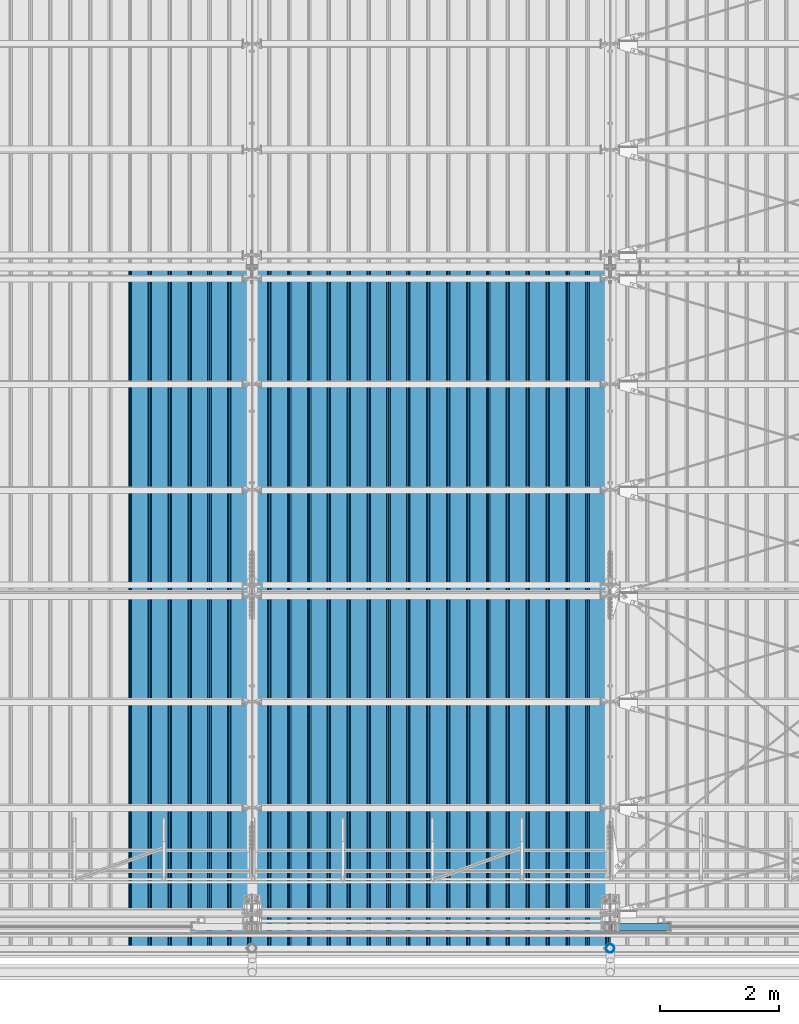
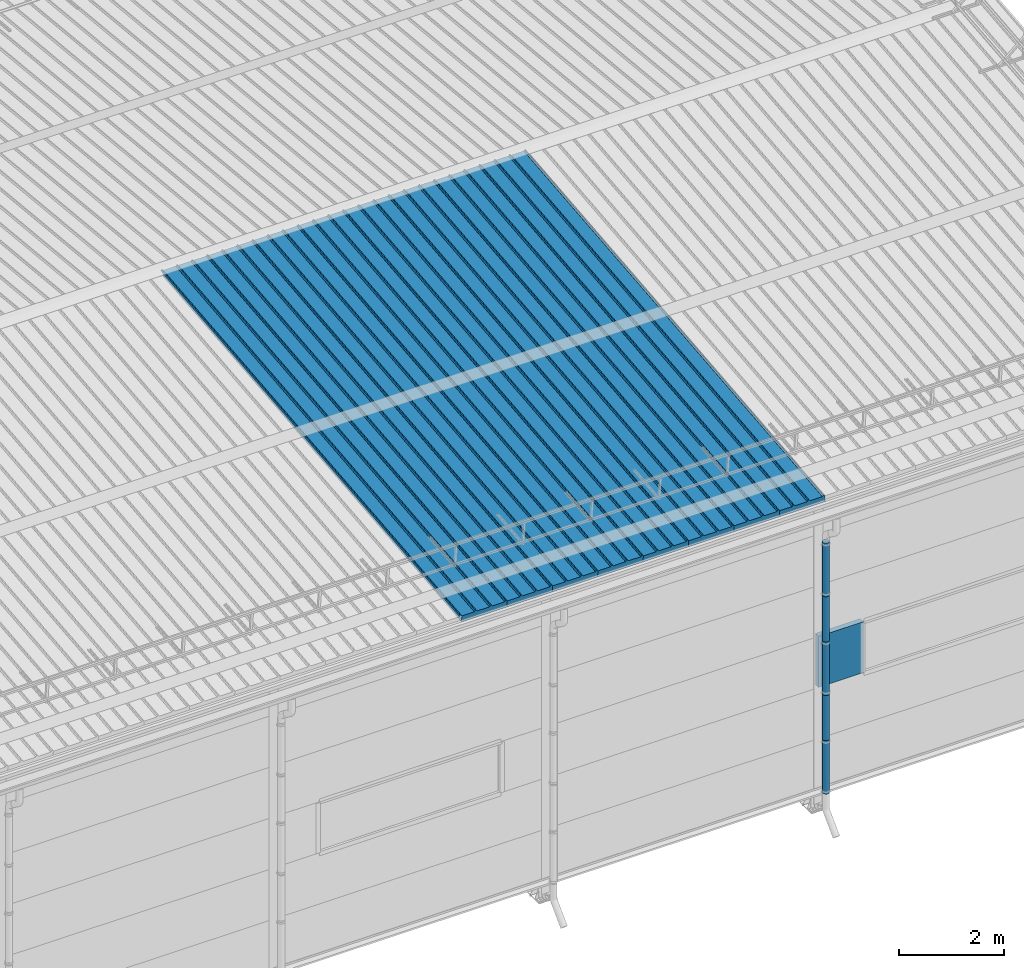
# One storey, part 65 of 709: 14 beams, 14 elements without a shape of their own.
"""IFC4 building model written with IfcOpenShell, lengths in millimetres."""

from ifc_helpers import new_model, si_unit, direction, frame, origin_with_axes, place, context, subcontext, project, spatial, line, indexed_curve, outline, extrude, material, element, aggregate, save


model = new_model("IFC4")

# Units and contexts
model_context = context("Model", 3, precision=0.2, world=origin_with_axes(), true_north=direction((0.0, 1.0)))
body_context = subcontext(model_context, "Body", "Model", "MODEL_VIEW")
ifc_project = project(units=[si_unit("LENGTHUNIT", "METRE", prefix="MILLI"), si_unit("AREAUNIT", "SQUARE_METRE"), si_unit("VOLUMEUNIT", "CUBIC_METRE"), si_unit("MASSUNIT", "GRAM", prefix="KILO"), si_unit("TIMEUNIT", "SECOND"), si_unit("PLANEANGLEUNIT", "RADIAN"), si_unit("SOLIDANGLEUNIT", "STERADIAN"), si_unit("THERMODYNAMICTEMPERATUREUNIT", "DEGREE_CELSIUS"), si_unit("LUMINOUSINTENSITYUNIT", "LUMEN")], contexts=[model_context])

# Site, building, storey
site_placement = place(None, origin_with_axes())
site = spatial("IfcSite", under=ifc_project, at=site_placement, CompositionType="ELEMENT")
building_placement = place(site_placement, origin_with_axes())
building = spatial("IfcBuilding", under=site, at=building_placement, Name="Undefined", CompositionType="ELEMENT")
storey_placement = place(building_placement, origin_with_axes())
storey = spatial("IfcBuildingStorey", under=building, at=storey_placement, Name="Undefined", CompositionType="ELEMENT", Elevation=0.0)

# Assembly, beam
assembly_1_placement = place(storey_placement, frame((39452.44, -410.89541, 7279.78979), z_axis=(1.0, 0.0, 0.0), x_axis=(0.0, 0.9950371902, 0.099503719)))
assembly_1 = element("IfcElementAssembly", 1, at=assembly_1_placement, inside=storey)
ifc_material_1 = material(Name="Insulation", Category="Insulation")
beam_1_placement = place(assembly_1_placement, origin_with_axes())
beam_1 = element("IfcBeam", 2, at=beam_1_placement, material=ifc_material_1, ObjectType="P-99", context=body_context, shape_type="SolidModel", body=[
    extrude(outline(indexed_curve([(-509.8453, 89.5), (-490.1547, 89.5), (-471.67949, 57.5), (-471.67949, -88.5), (-436.67949, -88.5), (-436.67949, -91.5), (562.55841, -91.5), (562.55841, -89.5), (527.55841, -89.5), (527.55841, 57.5), (510.2379, 88.5), (489.7621, 88.5), (472.44159, 58.5), (196.71923, 58.5), (177.66667, 91.5), (155.66667, 91.5), (136.61411, 58.5), (-136.61411, 58.5), (-155.66667, 91.5), (-177.66667, 91.5), (-196.71923, 58.5), (-469.94744, 58.5), (-489.0, 91.5), (-511.0, 91.5), (-527.16581, 63.5), (-525.43376, 62.5)], segments=[line(1, 2, 3, 4, 5, 6, 7, 8, 9, 10, 11, 12, 13, 14, 15, 16, 17, 18, 19, 20, 21, 22, 23, 24, 25, 26, 1)])), frame((0.0, 0.0, 0.0), z_axis=(-1.0, 0.0, 0.0), x_axis=(0.0, 0.0, 1.0)), (0.0, 0.0, -1.0), 11459.0),
])
aggregate(assembly_1, [beam_1])

assembly_2_placement = place(storey_placement, frame((38452.44, -410.89541, 7279.78979), z_axis=(1.0, 0.0, 0.0), x_axis=(0.0, 0.9950371902, 0.099503719)))
assembly_2 = element("IfcElementAssembly", 3, at=assembly_2_placement, inside=storey)
beam_2_placement = place(assembly_2_placement, origin_with_axes())
beam_2 = element("IfcBeam", 4, at=beam_2_placement, material=ifc_material_1, ObjectType="P-99", context=body_context, shape_type="SolidModel", body=[
    extrude(outline(indexed_curve([(-509.8453, 89.5), (-490.1547, 89.5), (-471.67949, 57.5), (-471.67949, -88.5), (-436.67949, -88.5), (-436.67949, -91.5), (562.55841, -91.5), (562.55841, -89.5), (527.55841, -89.5), (527.55841, 57.5), (510.2379, 88.5), (489.7621, 88.5), (472.44159, 58.5), (196.71923, 58.5), (177.66667, 91.5), (155.66667, 91.5), (136.61411, 58.5), (-136.61411, 58.5), (-155.66667, 91.5), (-177.66667, 91.5), (-196.71923, 58.5), (-469.94744, 58.5), (-489.0, 91.5), (-511.0, 91.5), (-527.16581, 63.5), (-525.43376, 62.5)], segments=[line(1, 2, 3, 4, 5, 6, 7, 8, 9, 10, 11, 12, 13, 14, 15, 16, 17, 18, 19, 20, 21, 22, 23, 24, 25, 26, 1)])), frame((0.0, 0.0, 0.0), z_axis=(-1.0, 0.0, 0.0), x_axis=(0.0, 0.0, 1.0)), (0.0, 0.0, -1.0), 11459.0),
])
aggregate(assembly_2, [beam_2])

assembly_3_placement = place(storey_placement, frame((37452.44, -410.89541, 7279.78979), z_axis=(1.0, 0.0, 0.0), x_axis=(0.0, 0.9950371902, 0.099503719)))
assembly_3 = element("IfcElementAssembly", 5, at=assembly_3_placement, inside=storey)
beam_3_placement = place(assembly_3_placement, origin_with_axes())
beam_3 = element("IfcBeam", 6, at=beam_3_placement, material=ifc_material_1, ObjectType="P-99", context=body_context, shape_type="SolidModel", body=[
    extrude(outline(indexed_curve([(-509.8453, 89.5), (-490.1547, 89.5), (-471.67949, 57.5), (-471.67949, -88.5), (-436.67949, -88.5), (-436.67949, -91.5), (562.55841, -91.5), (562.55841, -89.5), (527.55841, -89.5), (527.55841, 57.5), (510.2379, 88.5), (489.7621, 88.5), (472.44159, 58.5), (196.71923, 58.5), (177.66667, 91.5), (155.66667, 91.5), (136.61411, 58.5), (-136.61411, 58.5), (-155.66667, 91.5), (-177.66667, 91.5), (-196.71923, 58.5), (-469.94744, 58.5), (-489.0, 91.5), (-511.0, 91.5), (-527.16581, 63.5), (-525.43376, 62.5)], segments=[line(1, 2, 3, 4, 5, 6, 7, 8, 9, 10, 11, 12, 13, 14, 15, 16, 17, 18, 19, 20, 21, 22, 23, 24, 25, 26, 1)])), frame((0.0, 0.0, 0.0), z_axis=(-1.0, 0.0, 0.0), x_axis=(0.0, 0.0, 1.0)), (0.0, 0.0, -1.0), 11459.0),
])
aggregate(assembly_3, [beam_3])

assembly_4_placement = place(storey_placement, frame((36452.44, -410.89541, 7279.78979), z_axis=(1.0, 0.0, 0.0), x_axis=(0.0, 0.9950371902, 0.099503719)))
assembly_4 = element("IfcElementAssembly", 7, at=assembly_4_placement, inside=storey)
beam_4_placement = place(assembly_4_placement, origin_with_axes())
beam_4 = element("IfcBeam", 8, at=beam_4_placement, material=ifc_material_1, ObjectType="P-99", context=body_context, shape_type="SolidModel", body=[
    extrude(outline(indexed_curve([(-509.8453, 89.5), (-490.1547, 89.5), (-471.67949, 57.5), (-471.67949, -88.5), (-436.67949, -88.5), (-436.67949, -91.5), (562.55841, -91.5), (562.55841, -89.5), (527.55841, -89.5), (527.55841, 57.5), (510.2379, 88.5), (489.7621, 88.5), (472.44159, 58.5), (196.71923, 58.5), (177.66667, 91.5), (155.66667, 91.5), (136.61411, 58.5), (-136.61411, 58.5), (-155.66667, 91.5), (-177.66667, 91.5), (-196.71923, 58.5), (-469.94744, 58.5), (-489.0, 91.5), (-511.0, 91.5), (-527.16581, 63.5), (-525.43376, 62.5)], segments=[line(1, 2, 3, 4, 5, 6, 7, 8, 9, 10, 11, 12, 13, 14, 15, 16, 17, 18, 19, 20, 21, 22, 23, 24, 25, 26, 1)])), frame((0.0, 0.0, 0.0), z_axis=(-1.0, 0.0, 0.0), x_axis=(0.0, 0.0, 1.0)), (0.0, 0.0, -1.0), 11459.0),
])
aggregate(assembly_4, [beam_4])

assembly_5_placement = place(storey_placement, frame((35452.44, -410.89541, 7279.78979), z_axis=(1.0, 0.0, 0.0), x_axis=(0.0, 0.9950371902, 0.099503719)))
assembly_5 = element("IfcElementAssembly", 9, at=assembly_5_placement, inside=storey)
beam_5_placement = place(assembly_5_placement, origin_with_axes())
beam_5 = element("IfcBeam", 10, at=beam_5_placement, material=ifc_material_1, ObjectType="P-99", context=body_context, shape_type="SolidModel", body=[
    extrude(outline(indexed_curve([(-509.8453, 89.5), (-490.1547, 89.5), (-471.67949, 57.5), (-471.67949, -88.5), (-436.67949, -88.5), (-436.67949, -91.5), (562.55841, -91.5), (562.55841, -89.5), (527.55841, -89.5), (527.55841, 57.5), (510.2379, 88.5), (489.7621, 88.5), (472.44159, 58.5), (196.71923, 58.5), (177.66667, 91.5), (155.66667, 91.5), (136.61411, 58.5), (-136.61411, 58.5), (-155.66667, 91.5), (-177.66667, 91.5), (-196.71923, 58.5), (-469.94744, 58.5), (-489.0, 91.5), (-511.0, 91.5), (-527.16581, 63.5), (-525.43376, 62.5)], segments=[line(1, 2, 3, 4, 5, 6, 7, 8, 9, 10, 11, 12, 13, 14, 15, 16, 17, 18, 19, 20, 21, 22, 23, 24, 25, 26, 1)])), frame((0.0, 0.0, 0.0), z_axis=(-1.0, 0.0, 0.0), x_axis=(0.0, 0.0, 1.0)), (0.0, 0.0, -1.0), 11459.0),
])
aggregate(assembly_5, [beam_5])

assembly_6_placement = place(storey_placement, frame((34452.44, -410.89541, 7279.78979), z_axis=(1.0, 0.0, 0.0), x_axis=(0.0, 0.9950371902, 0.099503719)))
assembly_6 = element("IfcElementAssembly", 11, at=assembly_6_placement, inside=storey)
beam_6_placement = place(assembly_6_placement, origin_with_axes())
beam_6 = element("IfcBeam", 12, at=beam_6_placement, material=ifc_material_1, ObjectType="P-99", context=body_context, shape_type="SolidModel", body=[
    extrude(outline(indexed_curve([(-509.8453, 89.5), (-490.1547, 89.5), (-471.67949, 57.5), (-471.67949, -88.5), (-436.67949, -88.5), (-436.67949, -91.5), (562.55841, -91.5), (562.55841, -89.5), (527.55841, -89.5), (527.55841, 57.5), (510.2379, 88.5), (489.7621, 88.5), (472.44159, 58.5), (196.71923, 58.5), (177.66667, 91.5), (155.66667, 91.5), (136.61411, 58.5), (-136.61411, 58.5), (-155.66667, 91.5), (-177.66667, 91.5), (-196.71923, 58.5), (-469.94744, 58.5), (-489.0, 91.5), (-511.0, 91.5), (-527.16581, 63.5), (-525.43376, 62.5)], segments=[line(1, 2, 3, 4, 5, 6, 7, 8, 9, 10, 11, 12, 13, 14, 15, 16, 17, 18, 19, 20, 21, 22, 23, 24, 25, 26, 1)])), frame((0.0, 0.0, 0.0), z_axis=(-1.0, 0.0, 0.0), x_axis=(0.0, 0.0, 1.0)), (0.0, 0.0, -1.0), 11459.0),
])
aggregate(assembly_6, [beam_6])

assembly_7_placement = place(storey_placement, frame((33452.44, -410.89541, 7279.78979), z_axis=(1.0, 0.0, 0.0), x_axis=(0.0, 0.9950371902, 0.099503719)))
assembly_7 = element("IfcElementAssembly", 13, at=assembly_7_placement, inside=storey)
beam_7_placement = place(assembly_7_placement, origin_with_axes())
beam_7 = element("IfcBeam", 14, at=beam_7_placement, material=ifc_material_1, ObjectType="P-99", context=body_context, shape_type="SolidModel", body=[
    extrude(outline(indexed_curve([(-509.8453, 89.5), (-490.1547, 89.5), (-471.67949, 57.5), (-471.67949, -88.5), (-436.67949, -88.5), (-436.67949, -91.5), (562.55841, -91.5), (562.55841, -89.5), (527.55841, -89.5), (527.55841, 57.5), (510.2379, 88.5), (489.7621, 88.5), (472.44159, 58.5), (196.71923, 58.5), (177.66667, 91.5), (155.66667, 91.5), (136.61411, 58.5), (-136.61411, 58.5), (-155.66667, 91.5), (-177.66667, 91.5), (-196.71923, 58.5), (-469.94744, 58.5), (-489.0, 91.5), (-511.0, 91.5), (-527.16581, 63.5), (-525.43376, 62.5)], segments=[line(1, 2, 3, 4, 5, 6, 7, 8, 9, 10, 11, 12, 13, 14, 15, 16, 17, 18, 19, 20, 21, 22, 23, 24, 25, 26, 1)])), frame((0.0, 0.0, 0.0), z_axis=(-1.0, 0.0, 0.0), x_axis=(0.0, 0.0, 1.0)), (0.0, 0.0, -1.0), 11459.0),
])
aggregate(assembly_7, [beam_7])

assembly_8_placement = place(storey_placement, frame((32452.44, -410.89541, 7279.78979), z_axis=(1.0, 0.0, 0.0), x_axis=(0.0, 0.9950371902, 0.099503719)))
assembly_8 = element("IfcElementAssembly", 15, at=assembly_8_placement, inside=storey)
beam_8_placement = place(assembly_8_placement, origin_with_axes())
beam_8 = element("IfcBeam", 16, at=beam_8_placement, material=ifc_material_1, ObjectType="P-99", context=body_context, shape_type="SolidModel", body=[
    extrude(outline(indexed_curve([(-509.8453, 89.5), (-490.1547, 89.5), (-471.67949, 57.5), (-471.67949, -88.5), (-436.67949, -88.5), (-436.67949, -91.5), (562.55841, -91.5), (562.55841, -89.5), (527.55841, -89.5), (527.55841, 57.5), (510.2379, 88.5), (489.7621, 88.5), (472.44159, 58.5), (196.71923, 58.5), (177.66667, 91.5), (155.66667, 91.5), (136.61411, 58.5), (-136.61411, 58.5), (-155.66667, 91.5), (-177.66667, 91.5), (-196.71923, 58.5), (-469.94744, 58.5), (-489.0, 91.5), (-511.0, 91.5), (-527.16581, 63.5), (-525.43376, 62.5)], segments=[line(1, 2, 3, 4, 5, 6, 7, 8, 9, 10, 11, 12, 13, 14, 15, 16, 17, 18, 19, 20, 21, 22, 23, 24, 25, 26, 1)])), frame((0.0, 0.0, 0.0), z_axis=(-1.0, 0.0, 0.0), x_axis=(0.0, 0.0, 1.0)), (0.0, 0.0, -1.0), 11459.0),
])
aggregate(assembly_8, [beam_8])

assembly_9_placement = place(storey_placement, frame((40010.0, -60.0, 3275.0), z_axis=(0.0, 0.0, -1.0), x_axis=(1.0, 0.0, 0.0)))
assembly_9 = element("IfcElementAssembly", 17, at=assembly_9_placement, inside=storey)
beam_9_placement = place(assembly_9_placement, origin_with_axes())
beam_9 = element("IfcBeam", 18, at=beam_9_placement, material=ifc_material_1, ObjectType="P-110", context=body_context, shape_type="SolidModel", body=[
    extrude(outline(indexed_curve([(-595.0, -60.0), (595.0, -60.0), (595.0, 60.0), (-595.0, 60.0)], segments=[line(1, 2, 3, 4, 1)])), frame((0.0, 0.0, 0.0), z_axis=(-1.0, 0.0, 0.0), x_axis=(0.0, 0.0, 1.0)), (0.0, 0.0, -1.0), 990.0),
])
aggregate(assembly_9, [beam_9])

assembly_10_placement = place(storey_placement, frame((40000.0, -420.0, 6276.92297), z_axis=(0.0, 1.0, 0.0), x_axis=(0.0, 0.0, -1.0)))
assembly_10 = element("IfcElementAssembly", 19, at=assembly_10_placement, inside=storey)
ifc_material_2 = material(Name="Steel_Undefined", Category="STEEL")
beam_10_placement = place(assembly_10_placement, origin_with_axes())
beam_10 = element("IfcBeam", 20, at=beam_10_placement, material=ifc_material_2, ObjectType="614", context=body_context, shape_type="SolidModel", body=[
    extrude(outline(indexed_curve([(70.0, 0.0), (69.61653, 7.31699), (68.47033, 14.55382), (66.57396, 21.63119), (63.94818, 28.47157), (60.62178, 35.0), (56.63119, 41.14497), (52.02014, 46.83914), (46.83914, 52.02014), (41.14497, 56.63119), (35.0, 60.62178), (28.47157, 63.94818), (21.63119, 66.57396), (14.55382, 68.47033), (7.31699, 69.61653), (0.0, 70.0), (-7.31699, 69.61653), (-14.55382, 68.47033), (-21.63119, 66.57396), (-28.47157, 63.94818), (-35.0, 60.62178), (-41.14497, 56.63119), (-46.83914, 52.02014), (-52.02014, 46.83914), (-56.63119, 41.14497), (-60.62178, 35.0), (-63.94818, 28.47157), (-66.57396, 21.63119), (-68.47033, 14.55382), (-69.61653, 7.31699), (-70.0, 0.0), (-69.61653, -7.31699), (-68.47033, -14.55382), (-66.57396, -21.63119), (-63.94818, -28.47157), (-60.62178, -35.0), (-56.63119, -41.14497), (-52.02014, -46.83914), (-46.83914, -52.02014), (-41.14497, -56.63119), (-35.0, -60.62178), (-28.47157, -63.94818), (-21.63119, -66.57396), (-14.55382, -68.47033), (-7.31699, -69.61653), (0.0, -70.0), (7.31699, -69.61653), (14.55382, -68.47033), (21.63119, -66.57396), (28.47157, -63.94818), (35.0, -60.62178), (41.14497, -56.63119), (46.83914, -52.02014), (52.02014, -46.83914), (56.63119, -41.14497), (60.62178, -35.0), (63.94818, -28.47157), (66.57396, -21.63119), (68.47033, -14.55382), (69.61653, -7.31699)], segments=[line(1, 2, 3, 4, 5, 6, 7, 8, 9, 10, 11, 12, 13, 14, 15, 16, 17, 18, 19, 20, 21, 22, 23, 24, 25, 26, 27, 28, 29, 30, 31, 32, 33, 34, 35, 36, 37, 38, 39, 40, 41, 42, 43, 44, 45, 46, 47, 48, 49, 50, 51, 52, 53, 54, 55, 56, 57, 58, 59, 60, 1)]), holes=[indexed_curve([(65.0, 0.0), (64.64392, -6.79435), (63.57959, -13.51426), (61.81867, -20.0861), (59.38045, -26.43788), (56.29165, -32.5), (52.5861, -38.20604), (48.30441, -43.49349), (43.49349, -48.30441), (38.20604, -52.5861), (32.5, -56.29165), (26.43788, -59.38045), (20.0861, -61.81867), (13.51426, -63.57959), (6.79435, -64.64392), (0.0, -65.0), (-6.79435, -64.64392), (-13.51426, -63.57959), (-20.0861, -61.81867), (-26.43788, -59.38045), (-32.5, -56.29165), (-38.20604, -52.5861), (-43.49349, -48.30441), (-48.30441, -43.49349), (-52.5861, -38.20604), (-56.29165, -32.5), (-59.38045, -26.43788), (-61.81867, -20.0861), (-63.57959, -13.51426), (-64.64392, -6.79435), (-65.0, 0.0), (-64.64392, 6.79435), (-63.57959, 13.51426), (-61.81867, 20.0861), (-59.38045, 26.43788), (-56.29165, 32.5), (-52.5861, 38.20604), (-48.30441, 43.49349), (-43.49349, 48.30441), (-38.20604, 52.5861), (-32.5, 56.29165), (-26.43788, 59.38045), (-20.0861, 61.81867), (-13.51426, 63.57959), (-6.79435, 64.64392), (0.0, 65.0), (6.79435, 64.64392), (13.51426, 63.57959), (20.0861, 61.81867), (26.43788, 59.38045), (32.5, 56.29165), (38.20604, 52.5861), (43.49349, 48.30441), (48.30441, 43.49349), (52.5861, 38.20604), (56.29165, 32.5), (59.38045, 26.43788), (61.81867, 20.0861), (63.57959, 13.51426), (64.64392, 6.79435)], segments=[line(1, 2, 3, 4, 5, 6, 7, 8, 9, 10, 11, 12, 13, 14, 15, 16, 17, 18, 19, 20, 21, 22, 23, 24, 25, 26, 27, 28, 29, 30, 31, 32, 33, 34, 35, 36, 37, 38, 39, 40, 41, 42, 43, 44, 45, 46, 47, 48, 49, 50, 51, 52, 53, 54, 55, 56, 57, 58, 59, 60, 1)])]), frame((0.0, 0.0, 0.0), z_axis=(-1.0, 0.0, 0.0), x_axis=(0.0, 0.0, 1.0)), (0.0, 0.0, -1.0), 1250.0),
])
aggregate(assembly_10, [beam_10])

assembly_11_placement = place(storey_placement, frame((40000.0, -420.0, 5126.92297), z_axis=(0.0, 1.0, 0.0), x_axis=(0.0, 0.0, -1.0)))
assembly_11 = element("IfcElementAssembly", 21, at=assembly_11_placement, inside=storey)
beam_11_placement = place(assembly_11_placement, origin_with_axes())
beam_11 = element("IfcBeam", 22, at=beam_11_placement, material=ifc_material_2, ObjectType="614", context=body_context, shape_type="SolidModel", body=[
    extrude(outline(indexed_curve([(70.0, 0.0), (69.61653, 7.31699), (68.47033, 14.55382), (66.57396, 21.63119), (63.94818, 28.47157), (60.62178, 35.0), (56.63119, 41.14497), (52.02014, 46.83914), (46.83914, 52.02014), (41.14497, 56.63119), (35.0, 60.62178), (28.47157, 63.94818), (21.63119, 66.57396), (14.55382, 68.47033), (7.31699, 69.61653), (0.0, 70.0), (-7.31699, 69.61653), (-14.55382, 68.47033), (-21.63119, 66.57396), (-28.47157, 63.94818), (-35.0, 60.62178), (-41.14497, 56.63119), (-46.83914, 52.02014), (-52.02014, 46.83914), (-56.63119, 41.14497), (-60.62178, 35.0), (-63.94818, 28.47157), (-66.57396, 21.63119), (-68.47033, 14.55382), (-69.61653, 7.31699), (-70.0, 0.0), (-69.61653, -7.31699), (-68.47033, -14.55382), (-66.57396, -21.63119), (-63.94818, -28.47157), (-60.62178, -35.0), (-56.63119, -41.14497), (-52.02014, -46.83914), (-46.83914, -52.02014), (-41.14497, -56.63119), (-35.0, -60.62178), (-28.47157, -63.94818), (-21.63119, -66.57396), (-14.55382, -68.47033), (-7.31699, -69.61653), (0.0, -70.0), (7.31699, -69.61653), (14.55382, -68.47033), (21.63119, -66.57396), (28.47157, -63.94818), (35.0, -60.62178), (41.14497, -56.63119), (46.83914, -52.02014), (52.02014, -46.83914), (56.63119, -41.14497), (60.62178, -35.0), (63.94818, -28.47157), (66.57396, -21.63119), (68.47033, -14.55382), (69.61653, -7.31699)], segments=[line(1, 2, 3, 4, 5, 6, 7, 8, 9, 10, 11, 12, 13, 14, 15, 16, 17, 18, 19, 20, 21, 22, 23, 24, 25, 26, 27, 28, 29, 30, 31, 32, 33, 34, 35, 36, 37, 38, 39, 40, 41, 42, 43, 44, 45, 46, 47, 48, 49, 50, 51, 52, 53, 54, 55, 56, 57, 58, 59, 60, 1)]), holes=[indexed_curve([(65.0, 0.0), (64.64392, -6.79435), (63.57959, -13.51426), (61.81867, -20.0861), (59.38045, -26.43788), (56.29165, -32.5), (52.5861, -38.20604), (48.30441, -43.49349), (43.49349, -48.30441), (38.20604, -52.5861), (32.5, -56.29165), (26.43788, -59.38045), (20.0861, -61.81867), (13.51426, -63.57959), (6.79435, -64.64392), (0.0, -65.0), (-6.79435, -64.64392), (-13.51426, -63.57959), (-20.0861, -61.81867), (-26.43788, -59.38045), (-32.5, -56.29165), (-38.20604, -52.5861), (-43.49349, -48.30441), (-48.30441, -43.49349), (-52.5861, -38.20604), (-56.29165, -32.5), (-59.38045, -26.43788), (-61.81867, -20.0861), (-63.57959, -13.51426), (-64.64392, -6.79435), (-65.0, 0.0), (-64.64392, 6.79435), (-63.57959, 13.51426), (-61.81867, 20.0861), (-59.38045, 26.43788), (-56.29165, 32.5), (-52.5861, 38.20604), (-48.30441, 43.49349), (-43.49349, 48.30441), (-38.20604, 52.5861), (-32.5, 56.29165), (-26.43788, 59.38045), (-20.0861, 61.81867), (-13.51426, 63.57959), (-6.79435, 64.64392), (0.0, 65.0), (6.79435, 64.64392), (13.51426, 63.57959), (20.0861, 61.81867), (26.43788, 59.38045), (32.5, 56.29165), (38.20604, 52.5861), (43.49349, 48.30441), (48.30441, 43.49349), (52.5861, 38.20604), (56.29165, 32.5), (59.38045, 26.43788), (61.81867, 20.0861), (63.57959, 13.51426), (64.64392, 6.79435)], segments=[line(1, 2, 3, 4, 5, 6, 7, 8, 9, 10, 11, 12, 13, 14, 15, 16, 17, 18, 19, 20, 21, 22, 23, 24, 25, 26, 27, 28, 29, 30, 31, 32, 33, 34, 35, 36, 37, 38, 39, 40, 41, 42, 43, 44, 45, 46, 47, 48, 49, 50, 51, 52, 53, 54, 55, 56, 57, 58, 59, 60, 1)])]), frame((0.0, 0.0, 0.0), z_axis=(-1.0, 0.0, 0.0), x_axis=(0.0, 0.0, 1.0)), (0.0, 0.0, -1.0), 1250.0),
])
aggregate(assembly_11, [beam_11])

assembly_12_placement = place(storey_placement, frame((40000.0, -420.0, 3976.92297), z_axis=(0.0, 1.0, 0.0), x_axis=(0.0, 0.0, -1.0)))
assembly_12 = element("IfcElementAssembly", 23, at=assembly_12_placement, inside=storey)
beam_12_placement = place(assembly_12_placement, origin_with_axes())
beam_12 = element("IfcBeam", 24, at=beam_12_placement, material=ifc_material_2, ObjectType="614", context=body_context, shape_type="SolidModel", body=[
    extrude(outline(indexed_curve([(70.0, 0.0), (69.61653, 7.31699), (68.47033, 14.55382), (66.57396, 21.63119), (63.94818, 28.47157), (60.62178, 35.0), (56.63119, 41.14497), (52.02014, 46.83914), (46.83914, 52.02014), (41.14497, 56.63119), (35.0, 60.62178), (28.47157, 63.94818), (21.63119, 66.57396), (14.55382, 68.47033), (7.31699, 69.61653), (0.0, 70.0), (-7.31699, 69.61653), (-14.55382, 68.47033), (-21.63119, 66.57396), (-28.47157, 63.94818), (-35.0, 60.62178), (-41.14497, 56.63119), (-46.83914, 52.02014), (-52.02014, 46.83914), (-56.63119, 41.14497), (-60.62178, 35.0), (-63.94818, 28.47157), (-66.57396, 21.63119), (-68.47033, 14.55382), (-69.61653, 7.31699), (-70.0, 0.0), (-69.61653, -7.31699), (-68.47033, -14.55382), (-66.57396, -21.63119), (-63.94818, -28.47157), (-60.62178, -35.0), (-56.63119, -41.14497), (-52.02014, -46.83914), (-46.83914, -52.02014), (-41.14497, -56.63119), (-35.0, -60.62178), (-28.47157, -63.94818), (-21.63119, -66.57396), (-14.55382, -68.47033), (-7.31699, -69.61653), (0.0, -70.0), (7.31699, -69.61653), (14.55382, -68.47033), (21.63119, -66.57396), (28.47157, -63.94818), (35.0, -60.62178), (41.14497, -56.63119), (46.83914, -52.02014), (52.02014, -46.83914), (56.63119, -41.14497), (60.62178, -35.0), (63.94818, -28.47157), (66.57396, -21.63119), (68.47033, -14.55382), (69.61653, -7.31699)], segments=[line(1, 2, 3, 4, 5, 6, 7, 8, 9, 10, 11, 12, 13, 14, 15, 16, 17, 18, 19, 20, 21, 22, 23, 24, 25, 26, 27, 28, 29, 30, 31, 32, 33, 34, 35, 36, 37, 38, 39, 40, 41, 42, 43, 44, 45, 46, 47, 48, 49, 50, 51, 52, 53, 54, 55, 56, 57, 58, 59, 60, 1)]), holes=[indexed_curve([(65.0, 0.0), (64.64392, -6.79435), (63.57959, -13.51426), (61.81867, -20.0861), (59.38045, -26.43788), (56.29165, -32.5), (52.5861, -38.20604), (48.30441, -43.49349), (43.49349, -48.30441), (38.20604, -52.5861), (32.5, -56.29165), (26.43788, -59.38045), (20.0861, -61.81867), (13.51426, -63.57959), (6.79435, -64.64392), (0.0, -65.0), (-6.79435, -64.64392), (-13.51426, -63.57959), (-20.0861, -61.81867), (-26.43788, -59.38045), (-32.5, -56.29165), (-38.20604, -52.5861), (-43.49349, -48.30441), (-48.30441, -43.49349), (-52.5861, -38.20604), (-56.29165, -32.5), (-59.38045, -26.43788), (-61.81867, -20.0861), (-63.57959, -13.51426), (-64.64392, -6.79435), (-65.0, 0.0), (-64.64392, 6.79435), (-63.57959, 13.51426), (-61.81867, 20.0861), (-59.38045, 26.43788), (-56.29165, 32.5), (-52.5861, 38.20604), (-48.30441, 43.49349), (-43.49349, 48.30441), (-38.20604, 52.5861), (-32.5, 56.29165), (-26.43788, 59.38045), (-20.0861, 61.81867), (-13.51426, 63.57959), (-6.79435, 64.64392), (0.0, 65.0), (6.79435, 64.64392), (13.51426, 63.57959), (20.0861, 61.81867), (26.43788, 59.38045), (32.5, 56.29165), (38.20604, 52.5861), (43.49349, 48.30441), (48.30441, 43.49349), (52.5861, 38.20604), (56.29165, 32.5), (59.38045, 26.43788), (61.81867, 20.0861), (63.57959, 13.51426), (64.64392, 6.79435)], segments=[line(1, 2, 3, 4, 5, 6, 7, 8, 9, 10, 11, 12, 13, 14, 15, 16, 17, 18, 19, 20, 21, 22, 23, 24, 25, 26, 27, 28, 29, 30, 31, 32, 33, 34, 35, 36, 37, 38, 39, 40, 41, 42, 43, 44, 45, 46, 47, 48, 49, 50, 51, 52, 53, 54, 55, 56, 57, 58, 59, 60, 1)])]), frame((0.0, 0.0, 0.0), z_axis=(-1.0, 0.0, 0.0), x_axis=(0.0, 0.0, 1.0)), (0.0, 0.0, -1.0), 1250.0),
])
aggregate(assembly_12, [beam_12])

assembly_13_placement = place(storey_placement, frame((40000.0, -420.0, 2826.92297), z_axis=(0.0, 1.0, 0.0), x_axis=(0.0, 0.0, -1.0)))
assembly_13 = element("IfcElementAssembly", 25, at=assembly_13_placement, inside=storey)
beam_13_placement = place(assembly_13_placement, origin_with_axes())
beam_13 = element("IfcBeam", 26, at=beam_13_placement, material=ifc_material_2, ObjectType="614", context=body_context, shape_type="SolidModel", body=[
    extrude(outline(indexed_curve([(70.0, 0.0), (69.61653, 7.31699), (68.47033, 14.55382), (66.57396, 21.63119), (63.94818, 28.47157), (60.62178, 35.0), (56.63119, 41.14497), (52.02014, 46.83914), (46.83914, 52.02014), (41.14497, 56.63119), (35.0, 60.62178), (28.47157, 63.94818), (21.63119, 66.57396), (14.55382, 68.47033), (7.31699, 69.61653), (0.0, 70.0), (-7.31699, 69.61653), (-14.55382, 68.47033), (-21.63119, 66.57396), (-28.47157, 63.94818), (-35.0, 60.62178), (-41.14497, 56.63119), (-46.83914, 52.02014), (-52.02014, 46.83914), (-56.63119, 41.14497), (-60.62178, 35.0), (-63.94818, 28.47157), (-66.57396, 21.63119), (-68.47033, 14.55382), (-69.61653, 7.31699), (-70.0, 0.0), (-69.61653, -7.31699), (-68.47033, -14.55382), (-66.57396, -21.63119), (-63.94818, -28.47157), (-60.62178, -35.0), (-56.63119, -41.14497), (-52.02014, -46.83914), (-46.83914, -52.02014), (-41.14497, -56.63119), (-35.0, -60.62178), (-28.47157, -63.94818), (-21.63119, -66.57396), (-14.55382, -68.47033), (-7.31699, -69.61653), (0.0, -70.0), (7.31699, -69.61653), (14.55382, -68.47033), (21.63119, -66.57396), (28.47157, -63.94818), (35.0, -60.62178), (41.14497, -56.63119), (46.83914, -52.02014), (52.02014, -46.83914), (56.63119, -41.14497), (60.62178, -35.0), (63.94818, -28.47157), (66.57396, -21.63119), (68.47033, -14.55382), (69.61653, -7.31699)], segments=[line(1, 2, 3, 4, 5, 6, 7, 8, 9, 10, 11, 12, 13, 14, 15, 16, 17, 18, 19, 20, 21, 22, 23, 24, 25, 26, 27, 28, 29, 30, 31, 32, 33, 34, 35, 36, 37, 38, 39, 40, 41, 42, 43, 44, 45, 46, 47, 48, 49, 50, 51, 52, 53, 54, 55, 56, 57, 58, 59, 60, 1)]), holes=[indexed_curve([(65.0, 0.0), (64.64392, -6.79435), (63.57959, -13.51426), (61.81867, -20.0861), (59.38045, -26.43788), (56.29165, -32.5), (52.5861, -38.20604), (48.30441, -43.49349), (43.49349, -48.30441), (38.20604, -52.5861), (32.5, -56.29165), (26.43788, -59.38045), (20.0861, -61.81867), (13.51426, -63.57959), (6.79435, -64.64392), (0.0, -65.0), (-6.79435, -64.64392), (-13.51426, -63.57959), (-20.0861, -61.81867), (-26.43788, -59.38045), (-32.5, -56.29165), (-38.20604, -52.5861), (-43.49349, -48.30441), (-48.30441, -43.49349), (-52.5861, -38.20604), (-56.29165, -32.5), (-59.38045, -26.43788), (-61.81867, -20.0861), (-63.57959, -13.51426), (-64.64392, -6.79435), (-65.0, 0.0), (-64.64392, 6.79435), (-63.57959, 13.51426), (-61.81867, 20.0861), (-59.38045, 26.43788), (-56.29165, 32.5), (-52.5861, 38.20604), (-48.30441, 43.49349), (-43.49349, 48.30441), (-38.20604, 52.5861), (-32.5, 56.29165), (-26.43788, 59.38045), (-20.0861, 61.81867), (-13.51426, 63.57959), (-6.79435, 64.64392), (0.0, 65.0), (6.79435, 64.64392), (13.51426, 63.57959), (20.0861, 61.81867), (26.43788, 59.38045), (32.5, 56.29165), (38.20604, 52.5861), (43.49349, 48.30441), (48.30441, 43.49349), (52.5861, 38.20604), (56.29165, 32.5), (59.38045, 26.43788), (61.81867, 20.0861), (63.57959, 13.51426), (64.64392, 6.79435)], segments=[line(1, 2, 3, 4, 5, 6, 7, 8, 9, 10, 11, 12, 13, 14, 15, 16, 17, 18, 19, 20, 21, 22, 23, 24, 25, 26, 27, 28, 29, 30, 31, 32, 33, 34, 35, 36, 37, 38, 39, 40, 41, 42, 43, 44, 45, 46, 47, 48, 49, 50, 51, 52, 53, 54, 55, 56, 57, 58, 59, 60, 1)])]), frame((0.0, 0.0, 0.0), z_axis=(-1.0, 0.0, 0.0), x_axis=(0.0, 0.0, 1.0)), (0.0, 0.0, -1.0), 1250.0),
])
aggregate(assembly_13, [beam_13])

assembly_14_placement = place(storey_placement, frame((40000.0, -420.0, 1676.92297), z_axis=(0.0, 1.0, 0.0), x_axis=(0.0, 0.0, -1.0)))
assembly_14 = element("IfcElementAssembly", 27, at=assembly_14_placement, inside=storey)
beam_14_placement = place(assembly_14_placement, origin_with_axes())
beam_14 = element("IfcBeam", 28, at=beam_14_placement, material=ifc_material_2, ObjectType="614", context=body_context, shape_type="SolidModel", body=[
    extrude(outline(indexed_curve([(70.0, 0.0), (69.61653, 7.31699), (68.47033, 14.55382), (66.57396, 21.63119), (63.94818, 28.47157), (60.62178, 35.0), (56.63119, 41.14497), (52.02014, 46.83914), (46.83914, 52.02014), (41.14497, 56.63119), (35.0, 60.62178), (28.47157, 63.94818), (21.63119, 66.57396), (14.55382, 68.47033), (7.31699, 69.61653), (0.0, 70.0), (-7.31699, 69.61653), (-14.55382, 68.47033), (-21.63119, 66.57396), (-28.47157, 63.94818), (-35.0, 60.62178), (-41.14497, 56.63119), (-46.83914, 52.02014), (-52.02014, 46.83914), (-56.63119, 41.14497), (-60.62178, 35.0), (-63.94818, 28.47157), (-66.57396, 21.63119), (-68.47033, 14.55382), (-69.61653, 7.31699), (-70.0, 0.0), (-69.61653, -7.31699), (-68.47033, -14.55382), (-66.57396, -21.63119), (-63.94818, -28.47157), (-60.62178, -35.0), (-56.63119, -41.14497), (-52.02014, -46.83914), (-46.83914, -52.02014), (-41.14497, -56.63119), (-35.0, -60.62178), (-28.47157, -63.94818), (-21.63119, -66.57396), (-14.55382, -68.47033), (-7.31699, -69.61653), (0.0, -70.0), (7.31699, -69.61653), (14.55382, -68.47033), (21.63119, -66.57396), (28.47157, -63.94818), (35.0, -60.62178), (41.14497, -56.63119), (46.83914, -52.02014), (52.02014, -46.83914), (56.63119, -41.14497), (60.62178, -35.0), (63.94818, -28.47157), (66.57396, -21.63119), (68.47033, -14.55382), (69.61653, -7.31699)], segments=[line(1, 2, 3, 4, 5, 6, 7, 8, 9, 10, 11, 12, 13, 14, 15, 16, 17, 18, 19, 20, 21, 22, 23, 24, 25, 26, 27, 28, 29, 30, 31, 32, 33, 34, 35, 36, 37, 38, 39, 40, 41, 42, 43, 44, 45, 46, 47, 48, 49, 50, 51, 52, 53, 54, 55, 56, 57, 58, 59, 60, 1)]), holes=[indexed_curve([(65.0, 0.0), (64.64392, -6.79435), (63.57959, -13.51426), (61.81867, -20.0861), (59.38045, -26.43788), (56.29165, -32.5), (52.5861, -38.20604), (48.30441, -43.49349), (43.49349, -48.30441), (38.20604, -52.5861), (32.5, -56.29165), (26.43788, -59.38045), (20.0861, -61.81867), (13.51426, -63.57959), (6.79435, -64.64392), (0.0, -65.0), (-6.79435, -64.64392), (-13.51426, -63.57959), (-20.0861, -61.81867), (-26.43788, -59.38045), (-32.5, -56.29165), (-38.20604, -52.5861), (-43.49349, -48.30441), (-48.30441, -43.49349), (-52.5861, -38.20604), (-56.29165, -32.5), (-59.38045, -26.43788), (-61.81867, -20.0861), (-63.57959, -13.51426), (-64.64392, -6.79435), (-65.0, 0.0), (-64.64392, 6.79435), (-63.57959, 13.51426), (-61.81867, 20.0861), (-59.38045, 26.43788), (-56.29165, 32.5), (-52.5861, 38.20604), (-48.30441, 43.49349), (-43.49349, 48.30441), (-38.20604, 52.5861), (-32.5, 56.29165), (-26.43788, 59.38045), (-20.0861, 61.81867), (-13.51426, 63.57959), (-6.79435, 64.64392), (0.0, 65.0), (6.79435, 64.64392), (13.51426, 63.57959), (20.0861, 61.81867), (26.43788, 59.38045), (32.5, 56.29165), (38.20604, 52.5861), (43.49349, 48.30441), (48.30441, 43.49349), (52.5861, 38.20604), (56.29165, 32.5), (59.38045, 26.43788), (61.81867, 20.0861), (63.57959, 13.51426), (64.64392, 6.79435)], segments=[line(1, 2, 3, 4, 5, 6, 7, 8, 9, 10, 11, 12, 13, 14, 15, 16, 17, 18, 19, 20, 21, 22, 23, 24, 25, 26, 27, 28, 29, 30, 31, 32, 33, 34, 35, 36, 37, 38, 39, 40, 41, 42, 43, 44, 45, 46, 47, 48, 49, 50, 51, 52, 53, 54, 55, 56, 57, 58, 59, 60, 1)])]), frame((0.0, 0.0, 0.0), z_axis=(-1.0, 0.0, 0.0), x_axis=(0.0, 0.0, 1.0)), (0.0, 0.0, -1.0), 1250.0),
])
aggregate(assembly_14, [beam_14])

save(model, "model.ifc")
